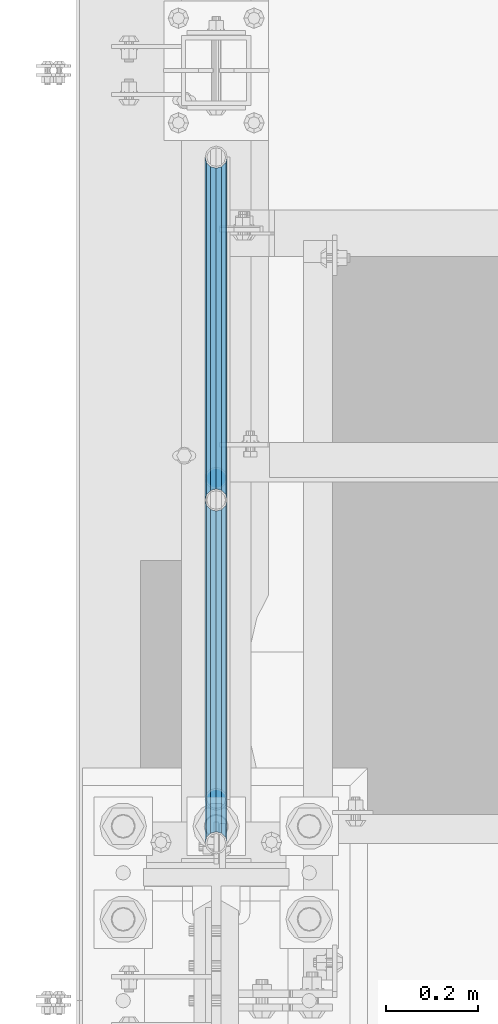
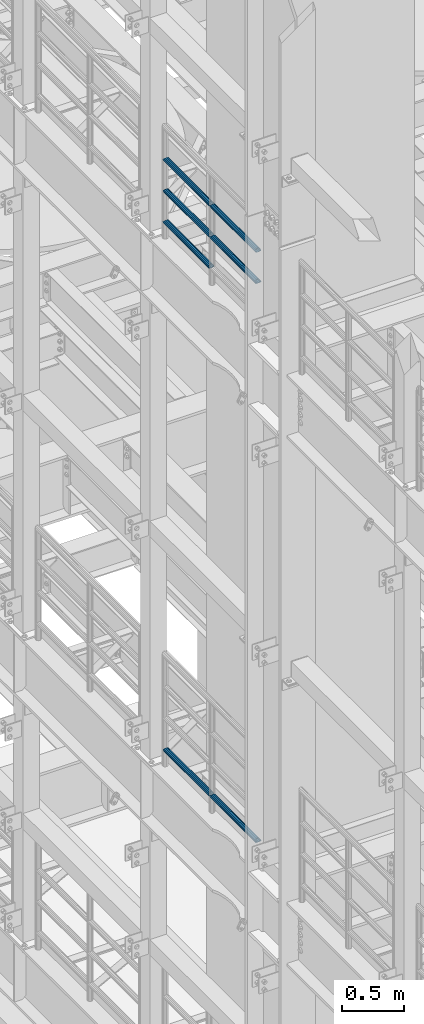
# One storey, part 1245 of 1876: 7 beams, 2 elements without a shape of their own.
"""IFC2X3 building model written with IfcOpenShell, lengths in millimetres."""

from ifc_helpers import new_model, si_unit, frame, origin_with_axes, place, context, subcontext, project, spatial, faceted_brep, material, type_object, element, aggregate, save


model = new_model("IFC2X3")

# Units and contexts
model_context = context("Model", 3, precision=1e-05, world=origin_with_axes())
body_context = subcontext(model_context, "Body", "Model", "MODEL_VIEW")
ifc_project = project(units=[si_unit("LENGTHUNIT", "METRE", prefix="MILLI"), si_unit("AREAUNIT", "SQUARE_METRE"), si_unit("VOLUMEUNIT", "CUBIC_METRE"), si_unit("MASSUNIT", "GRAM", prefix="KILO"), si_unit("TIMEUNIT", "SECOND"), si_unit("PLANEANGLEUNIT", "RADIAN"), si_unit("SOLIDANGLEUNIT", "STERADIAN"), si_unit("THERMODYNAMICTEMPERATUREUNIT", "DEGREE_CELSIUS"), si_unit("LUMINOUSINTENSITYUNIT", "LUMEN")], contexts=[model_context])

# Site, building, storey
site_placement = place(None, origin_with_axes())
site = spatial("IfcSite", under=ifc_project, at=site_placement, CompositionType="ELEMENT")
building_placement = place(site_placement, origin_with_axes())
building = spatial("IfcBuilding", under=site, at=building_placement, Name="Undefined", CompositionType="ELEMENT")
storey_placement = place(building_placement, origin_with_axes())
storey = spatial("IfcBuildingStorey", under=building, at=storey_placement, Name="Undefined", CompositionType="ELEMENT", Elevation=0.0)

# Assembly, beams
assembly_1_placement = place(storey_placement, origin_with_axes())
assembly_1 = element("IfcElementAssembly", 1, at=assembly_1_placement, inside=storey, Name="RAIL", AssemblyPlace="NOTDEFINED", PredefinedType="RIGID_FRAME")
ifc_material = material()
beam_type = type_object("IfcBeamType", Name="PIPE1-1/2SCH40", PredefinedType="NOTDEFINED")
beam_1_placement = place(assembly_1_placement, frame((-1.81898940354586e-12, 3366.77, 13471.525), z_axis=(0.0, 0.0, 1.0), x_axis=(0.0, -1.0, 0.0)))
beam_1 = element("IfcBeam", 2, at=beam_1_placement, type_object=beam_type, material=ifc_material, Name="RAIL", ObjectType="PIPE1-1/2SCH40", context=body_context, shape_type="Brep", body=[
    faceted_brep([(728.085307006683, -12.0649999999996, 20.8971929933177), (728.085307006683, -12.0649999999996, 15.8661214311796), (727.591878568821, -10.2235000000001, 17.7076214311819), (724.852500000002, 0.0, 20.4470000000001), (724.852500000002, 0.0, 24.130000000001), (727.591878568821, 10.2235000000001, 17.7076214311819), (728.085307006683, 12.0649999999996, 15.8661214311796), (728.085307006683, 12.0649999999996, 20.8971929933177), (748.982500000002, 24.1300000000001, 0.0), (736.917500000002, 20.8971929933186, 12.0649999999987), (736.917500000002, 20.8971929933186, -12.0649999999987), (733.727928437864, 17.7076214311801, 10.2235000000001), (736.467307006683, 20.4470000000001, 0.0), (733.727928437864, 17.7076214311801, -10.2235000000001), (728.085307006683, 12.0649999999996, -15.8661214311796), (728.085307006683, 12.0649999999996, -20.8971929933177), (727.591878568821, 10.2235000000001, -17.7076214311819), (724.852500000002, 0.0, -20.4470000000001), (724.852500000002, 0.0, -24.130000000001), (728.085307006683, -12.0649999999996, -15.8661214311796), (728.085307006683, -12.0649999999996, -20.8971929933177), (727.591878568821, -10.2235000000001, -17.7076214311819), (748.982500000002, -24.1300000000001, 0.0), (736.917500000002, -20.8971929933186, -12.0649999999987), (736.917500000002, -20.8971929933186, 12.0649999999987), (733.727928437864, -17.7076214311801, -10.2235000000001), (736.467307006683, -20.4470000000001, 0.0), (733.727928437864, -17.7076214311801, 10.2235000000001), (12.0650000000064, -20.8971929933177, -12.0649999999987), (20.8971929933249, -12.0650000000005, -20.8971929933177), (0.0, 24.1299999999992, 0.0), (12.0650000000064, 20.8971929933177, -12.0649999999987), (12.0650000000064, 20.8971929933177, 12.0649999999987), (20.8971929933249, 12.0650000000005, 20.8971929933177), (24.1300000000064, 0.0, 24.130000000001), (20.8971929933249, 12.0650000000005, -20.8971929933177), (24.1300000000063, 0.0, -24.130000000001), (24.1300000000063, 0.0, -20.4470000000001), (20.8971929933249, -12.0650000000005, -15.8661214311796), (21.3906214311868, -10.2235000000001, -17.7076214311819), (21.3906214311868, 10.2235000000001, -17.7076214311819), (20.8971929933249, 12.0650000000005, -15.8661214311796), (15.2545715621445, 17.7076214311801, -10.2235000000001), (12.5151929933249, 20.4470000000001, 0.0), (15.2545715621445, 17.7076214311801, 10.2235000000001), (20.8971929933249, 12.0650000000005, 15.8661214311796), (21.3906214311868, 10.2235000000001, 17.7076214311819), (24.1300000000064, 0.0, 20.4470000000001), (21.3906214311868, -10.2235000000001, 17.7076214311819), (20.8971929933249, -12.0650000000005, 15.8661214311796), (20.8971929933249, -12.0650000000005, 20.8971929933177), (12.0650000000064, -20.8971929933177, 12.0649999999987), (0.0, -24.1299999999992, 0.0), (15.2545715621445, -17.7076214311801, 10.2235000000001), (12.5151929933249, -20.4470000000001, 0.0), (15.2545715621445, -17.7076214311801, -10.2235000000001)], [[[0, 1, 2, 3, 4]], [[4, 3, 5, 6, 7]], [[8, 9, 10]], [[7, 6, 11, 12, 13, 14, 15, 10, 9]], [[16, 17, 18, 15, 14]], [[19, 20, 18, 17, 21]], [[22, 23, 24]], [[24, 23, 20, 19, 25, 26, 27, 1, 0]], [[28, 29, 20, 23]], [[30, 31, 32]], [[33, 34, 4, 7]], [[32, 33, 7, 9]], [[30, 32, 9, 8]], [[31, 30, 8, 10]], [[35, 31, 10, 15]], [[36, 35, 15, 18]], [[29, 36, 18, 20]], [[37, 36, 29, 38, 39]], [[40, 41, 35, 36, 37]], [[32, 31, 35, 41, 42, 43, 44, 45, 33]], [[33, 45, 46, 47, 34]], [[34, 47, 48, 49, 50]], [[34, 50, 0, 4]], [[50, 51, 24, 0]], [[51, 52, 22, 24]], [[52, 28, 23, 22]], [[51, 28, 52]], [[50, 49, 53, 54, 55, 38, 29, 28, 51]], [[55, 54, 26, 25]], [[21, 39, 38, 55, 25, 19]], [[37, 39, 21, 17]], [[40, 37, 17, 16]], [[42, 41, 40, 16, 14, 13]], [[43, 42, 13, 12]], [[44, 43, 12, 11]], [[5, 46, 45, 44, 11, 6]], [[47, 46, 5, 3]], [[48, 47, 3, 2]], [[53, 49, 48, 2, 1, 27]], [[54, 53, 27, 26]]]),
])
beam_2_placement = place(assembly_1_placement, frame((-1.81898940354586e-12, 1868.805, 13776.325), z_axis=(0.0, 0.0, -1.0), x_axis=(0.0, 1.0, 0.0)))
beam_2 = element("IfcBeam", 3, at=beam_2_placement, type_object=beam_type, material=ifc_material, Name="RAIL", ObjectType="PIPE1-1/2SCH40", context=body_context, shape_type="Brep", body=[
    faceted_brep([(0.0, 24.1299999999992, 0.0), (12.0650000000064, 20.8971929933177, -12.0649999999987), (12.0650000000064, 20.8971929933177, 12.0649999999987), (12.0650000000064, -20.8971929933177, 12.0649999999987), (12.0650000000064, -20.8971929933177, -12.0649999999987), (0.0, -24.1299999999992, 0.0), (20.8971929933249, -12.0650000000005, 20.8971929933177), (20.8971929933249, -12.0650000000005, 15.8661214311796), (15.2545715621445, -17.7076214311801, 10.2235000000001), (12.5151929933249, -20.4470000000001, 0.0), (15.2545715621445, -17.7076214311801, -10.2235000000001), (20.8971929933249, -12.0650000000005, -15.8661214311796), (20.8971929933249, -12.0650000000005, -20.8971929933177), (24.1300000000063, 0.0, -20.4470000000001), (24.1300000000063, 0.0, -24.130000000001), (21.3906214311868, -10.2235000000001, -17.7076214311819), (21.3906214311868, 10.2235000000001, -17.7076214311819), (20.8971929933249, 12.0650000000005, -15.8661214311796), (20.8971929933249, 12.0650000000005, -20.8971929933177), (15.2545715621445, 17.7076214311801, -10.2235000000001), (12.5151929933249, 20.4470000000001, 0.0), (15.2545715621445, 17.7076214311801, 10.2235000000001), (20.8971929933249, 12.0650000000005, 15.8661214311796), (20.8971929933249, 12.0650000000005, 20.8971929933177), (21.3906214311868, 10.2235000000001, 17.7076214311819), (24.1300000000064, 0.0, 20.4470000000001), (24.1300000000064, 0.0, 24.130000000001), (21.3906214311868, -10.2235000000001, 17.7076214311819), (748.982500000002, 24.1300000000001, 0.0), (736.917500000002, 20.8971929933186, -12.0649999999987), (728.085307006683, 12.0649999999996, -20.8971929933177), (748.982500000002, -24.1300000000001, 0.0), (736.917500000002, -20.8971929933186, -12.0649999999987), (736.917500000002, -20.8971929933186, 12.0649999999987), (728.085307006683, -12.0649999999996, 20.8971929933177), (728.085307006683, -12.0649999999996, -20.8971929933177), (724.852500000002, 0.0, -24.130000000001), (727.591878568821, 10.2235000000001, -17.7076214311819), (724.852500000002, 0.0, -20.4470000000001), (728.085307006683, 12.0649999999996, -15.8661214311796), (728.085307006683, -12.0649999999996, -15.8661214311796), (727.591878568821, -10.2235000000001, -17.7076214311819), (733.727928437864, -17.7076214311801, -10.2235000000001), (736.467307006683, -20.4470000000001, 0.0), (733.727928437864, -17.7076214311801, 10.2235000000001), (728.085307006683, -12.0649999999996, 15.8661214311796), (727.591878568821, -10.2235000000001, 17.7076214311819), (724.852500000002, 0.0, 20.4470000000001), (724.852500000002, 0.0, 24.130000000001), (728.085307006683, 12.0649999999996, 20.8971929933177), (736.917500000002, 20.8971929933186, 12.0649999999987), (728.085307006683, 12.0649999999996, 15.8661214311796), (733.727928437864, 17.7076214311801, 10.2235000000001), (736.467307006683, 20.4470000000001, 0.0), (733.727928437864, 17.7076214311801, -10.2235000000001), (727.591878568821, 10.2235000000001, 17.7076214311819)], [[[0, 1, 2]], [[3, 4, 5]], [[6, 7, 8, 9, 10, 11, 12, 4, 3]], [[13, 14, 12, 11, 15]], [[16, 17, 18, 14, 13]], [[2, 1, 18, 17, 19, 20, 21, 22, 23]], [[23, 22, 24, 25, 26]], [[26, 25, 27, 7, 6]], [[1, 0, 28, 29]], [[18, 1, 29, 30]], [[31, 32, 33]], [[6, 3, 33, 34]], [[3, 5, 31, 33]], [[5, 4, 32, 31]], [[4, 12, 35, 32]], [[12, 14, 36, 35]], [[14, 18, 30, 36]], [[37, 38, 36, 30, 39]], [[40, 35, 36, 38, 41]], [[33, 32, 35, 40, 42, 43, 44, 45, 34]], [[34, 45, 46, 47, 48]], [[26, 6, 34, 48]], [[2, 23, 49, 50]], [[23, 26, 48, 49]], [[0, 2, 50, 28]], [[28, 50, 29]], [[49, 51, 52, 53, 54, 39, 30, 29, 50]], [[48, 47, 55, 51, 49]], [[25, 24, 55, 47]], [[55, 24, 22, 21, 52, 51]], [[21, 20, 53, 52]], [[20, 19, 54, 53]], [[19, 17, 16, 37, 39, 54]], [[16, 13, 38, 37]], [[13, 15, 41, 38]], [[41, 15, 11, 10, 42, 40]], [[10, 9, 43, 42]], [[9, 8, 44, 43]], [[8, 7, 27, 46, 45, 44]], [[27, 25, 47, 46]]]),
])
beam_3_placement = place(assembly_1_placement, frame((-1.81898940354586e-12, 2617.7875, 13776.325), z_axis=(0.0, 0.0, -1.0), x_axis=(0.0, 1.0, 0.0)))
beam_3 = element("IfcBeam", 4, at=beam_3_placement, type_object=beam_type, material=ifc_material, Name="RAIL", ObjectType="PIPE1-1/2SCH40", context=body_context, shape_type="Brep", body=[
    faceted_brep([(0.0, 24.1299999999992, 0.0), (12.0650000000064, 20.8971929933177, -12.0649999999987), (12.0650000000064, 20.8971929933177, 12.0649999999987), (12.0650000000064, -20.8971929933177, 12.0649999999987), (12.0650000000064, -20.8971929933177, -12.0649999999987), (0.0, -24.1299999999992, 0.0), (20.8971929933249, -12.0650000000005, 20.8971929933177), (20.8971929933249, -12.0650000000005, 15.8661214311796), (15.2545715621445, -17.7076214311801, 10.2235000000001), (12.5151929933249, -20.4470000000001, 0.0), (15.2545715621445, -17.7076214311801, -10.2235000000001), (20.8971929933249, -12.0650000000005, -15.8661214311796), (20.8971929933249, -12.0650000000005, -20.8971929933177), (24.1300000000063, 0.0, -20.4470000000001), (24.1300000000063, 0.0, -24.130000000001), (21.3906214311868, -10.2235000000001, -17.7076214311819), (21.3906214311868, 10.2235000000001, -17.7076214311819), (20.8971929933249, 12.0650000000005, -15.8661214311796), (20.8971929933249, 12.0650000000005, -20.8971929933177), (15.2545715621445, 17.7076214311801, -10.2235000000001), (12.5151929933249, 20.4470000000001, 0.0), (15.2545715621445, 17.7076214311801, 10.2235000000001), (20.8971929933249, 12.0650000000005, 15.8661214311796), (20.8971929933249, 12.0650000000005, 20.8971929933177), (21.3906214311868, 10.2235000000001, 17.7076214311819), (24.1300000000064, 0.0, 20.4470000000001), (24.1300000000064, 0.0, 24.130000000001), (21.3906214311868, -10.2235000000001, 17.7076214311819), (748.982500000002, 24.1300000000001, 0.0), (736.917500000002, 20.8971929933186, -12.0649999999987), (728.085307006683, 12.0649999999996, -20.8971929933177), (748.982500000002, -24.1300000000001, 0.0), (736.917500000002, -20.8971929933186, -12.0649999999987), (736.917500000002, -20.8971929933186, 12.0649999999987), (728.085307006683, -12.0649999999996, 20.8971929933177), (728.085307006683, -12.0649999999996, -20.8971929933177), (724.852500000002, 0.0, -24.130000000001), (727.591878568821, 10.2235000000001, -17.7076214311819), (724.852500000002, 0.0, -20.4470000000001), (728.085307006683, 12.0649999999996, -15.8661214311796), (728.085307006683, -12.0649999999996, -15.8661214311796), (727.591878568821, -10.2235000000001, -17.7076214311819), (733.727928437864, -17.7076214311801, -10.2235000000001), (736.467307006683, -20.4470000000001, 0.0), (733.727928437864, -17.7076214311801, 10.2235000000001), (728.085307006683, -12.0649999999996, 15.8661214311796), (727.591878568821, -10.2235000000001, 17.7076214311819), (724.852500000002, 0.0, 20.4470000000001), (724.852500000002, 0.0, 24.130000000001), (728.085307006683, 12.0649999999996, 20.8971929933177), (736.917500000002, 20.8971929933186, 12.0649999999987), (728.085307006683, 12.0649999999996, 15.8661214311796), (733.727928437864, 17.7076214311801, 10.2235000000001), (736.467307006683, 20.4470000000001, 0.0), (733.727928437864, 17.7076214311801, -10.2235000000001), (727.591878568821, 10.2235000000001, 17.7076214311819)], [[[0, 1, 2]], [[3, 4, 5]], [[6, 7, 8, 9, 10, 11, 12, 4, 3]], [[13, 14, 12, 11, 15]], [[16, 17, 18, 14, 13]], [[2, 1, 18, 17, 19, 20, 21, 22, 23]], [[23, 22, 24, 25, 26]], [[26, 25, 27, 7, 6]], [[1, 0, 28, 29]], [[18, 1, 29, 30]], [[31, 32, 33]], [[6, 3, 33, 34]], [[3, 5, 31, 33]], [[5, 4, 32, 31]], [[4, 12, 35, 32]], [[12, 14, 36, 35]], [[14, 18, 30, 36]], [[37, 38, 36, 30, 39]], [[40, 35, 36, 38, 41]], [[33, 32, 35, 40, 42, 43, 44, 45, 34]], [[34, 45, 46, 47, 48]], [[26, 6, 34, 48]], [[2, 23, 49, 50]], [[23, 26, 48, 49]], [[0, 2, 50, 28]], [[28, 50, 29]], [[49, 51, 52, 53, 54, 39, 30, 29, 50]], [[48, 47, 55, 51, 49]], [[25, 24, 55, 47]], [[55, 24, 22, 21, 52, 51]], [[21, 20, 53, 52]], [[20, 19, 54, 53]], [[19, 17, 16, 37, 39, 54]], [[16, 13, 38, 37]], [[13, 15, 41, 38]], [[41, 15, 11, 10, 42, 40]], [[10, 9, 43, 42]], [[9, 8, 44, 43]], [[8, 7, 27, 46, 45, 44]], [[27, 25, 47, 46]]]),
])
beam_4_placement = place(assembly_1_placement, frame((-1.81898940354586e-12, 1868.805, 14081.125), z_axis=(0.0, 0.0, -1.0), x_axis=(0.0, 1.0, 0.0)))
beam_4 = element("IfcBeam", 5, at=beam_4_placement, type_object=beam_type, material=ifc_material, Name="RAIL", ObjectType="PIPE1-1/2SCH40", context=body_context, shape_type="Brep", body=[
    faceted_brep([(0.0, 24.1299999999992, 0.0), (12.0650000000064, 20.8971929933177, -12.0649999999987), (12.0650000000064, 20.8971929933177, 12.0649999999987), (12.0650000000064, -20.8971929933177, 12.0649999999987), (12.0650000000064, -20.8971929933177, -12.0649999999987), (0.0, -24.1299999999992, 0.0), (20.8971929933249, -12.0650000000005, 20.8971929933177), (20.8971929933249, -12.0650000000005, 15.8661214311796), (15.2545715621445, -17.7076214311801, 10.2235000000001), (12.5151929933249, -20.4470000000001, 0.0), (15.2545715621445, -17.7076214311801, -10.2235000000001), (20.8971929933249, -12.0650000000005, -15.8661214311796), (20.8971929933249, -12.0650000000005, -20.8971929933177), (24.1300000000063, 0.0, -20.4470000000001), (24.1300000000063, 0.0, -24.130000000001), (21.3906214311868, -10.2235000000001, -17.7076214311819), (21.3906214311868, 10.2235000000001, -17.7076214311819), (20.8971929933249, 12.0650000000005, -15.8661214311796), (20.8971929933249, 12.0650000000005, -20.8971929933177), (15.2545715621445, 17.7076214311801, -10.2235000000001), (12.5151929933249, 20.4470000000001, 0.0), (15.2545715621445, 17.7076214311801, 10.2235000000001), (20.8971929933249, 12.0650000000005, 15.8661214311796), (20.8971929933249, 12.0650000000005, 20.8971929933177), (21.3906214311868, 10.2235000000001, 17.7076214311819), (24.1300000000064, 0.0, 20.4470000000001), (24.1300000000064, 0.0, 24.130000000001), (21.3906214311868, -10.2235000000001, 17.7076214311819), (748.982500000002, 24.1300000000001, 0.0), (736.917500000002, 20.8971929933186, -12.0649999999987), (728.085307006683, 12.0649999999996, -20.8971929933177), (748.982500000002, -24.1300000000001, 0.0), (736.917500000002, -20.8971929933186, -12.0649999999987), (736.917500000002, -20.8971929933186, 12.0649999999987), (728.085307006683, -12.0649999999996, 20.8971929933177), (728.085307006683, -12.0649999999996, -20.8971929933177), (724.852500000002, 0.0, -24.130000000001), (727.591878568821, 10.2235000000001, -17.7076214311819), (724.852500000002, 0.0, -20.4470000000001), (728.085307006683, 12.0649999999996, -15.8661214311796), (728.085307006683, -12.0649999999996, -15.8661214311796), (727.591878568821, -10.2235000000001, -17.7076214311819), (733.727928437864, -17.7076214311801, -10.2235000000001), (736.467307006683, -20.4470000000001, 0.0), (733.727928437864, -17.7076214311801, 10.2235000000001), (728.085307006683, -12.0649999999996, 15.8661214311796), (727.591878568821, -10.2235000000001, 17.7076214311819), (724.852500000002, 0.0, 20.4470000000001), (724.852500000002, 0.0, 24.130000000001), (728.085307006683, 12.0649999999996, 20.8971929933177), (736.917500000002, 20.8971929933186, 12.0649999999987), (728.085307006683, 12.0649999999996, 15.8661214311796), (733.727928437864, 17.7076214311801, 10.2235000000001), (736.467307006683, 20.4470000000001, 0.0), (733.727928437864, 17.7076214311801, -10.2235000000001), (727.591878568821, 10.2235000000001, 17.7076214311819)], [[[0, 1, 2]], [[3, 4, 5]], [[6, 7, 8, 9, 10, 11, 12, 4, 3]], [[13, 14, 12, 11, 15]], [[16, 17, 18, 14, 13]], [[2, 1, 18, 17, 19, 20, 21, 22, 23]], [[23, 22, 24, 25, 26]], [[26, 25, 27, 7, 6]], [[1, 0, 28, 29]], [[18, 1, 29, 30]], [[31, 32, 33]], [[6, 3, 33, 34]], [[3, 5, 31, 33]], [[5, 4, 32, 31]], [[4, 12, 35, 32]], [[12, 14, 36, 35]], [[14, 18, 30, 36]], [[37, 38, 36, 30, 39]], [[40, 35, 36, 38, 41]], [[33, 32, 35, 40, 42, 43, 44, 45, 34]], [[34, 45, 46, 47, 48]], [[26, 6, 34, 48]], [[2, 23, 49, 50]], [[23, 26, 48, 49]], [[0, 2, 50, 28]], [[28, 50, 29]], [[49, 51, 52, 53, 54, 39, 30, 29, 50]], [[48, 47, 55, 51, 49]], [[25, 24, 55, 47]], [[55, 24, 22, 21, 52, 51]], [[21, 20, 53, 52]], [[20, 19, 54, 53]], [[19, 17, 16, 37, 39, 54]], [[16, 13, 38, 37]], [[13, 15, 41, 38]], [[41, 15, 11, 10, 42, 40]], [[10, 9, 43, 42]], [[9, 8, 44, 43]], [[8, 7, 27, 46, 45, 44]], [[27, 25, 47, 46]]]),
])
beam_5_placement = place(assembly_1_placement, frame((-1.81898940354586e-12, 2617.7875, 14081.125), z_axis=(0.0, 0.0, -1.0), x_axis=(0.0, 1.0, 0.0)))
beam_5 = element("IfcBeam", 6, at=beam_5_placement, type_object=beam_type, material=ifc_material, Name="RAIL", ObjectType="PIPE1-1/2SCH40", context=body_context, shape_type="Brep", body=[
    faceted_brep([(0.0, 24.1299999999992, 0.0), (12.0650000000064, 20.8971929933177, -12.0649999999987), (12.0650000000064, 20.8971929933177, 12.0649999999987), (12.0650000000064, -20.8971929933177, 12.0649999999987), (12.0650000000064, -20.8971929933177, -12.0649999999987), (0.0, -24.1299999999992, 0.0), (20.8971929933249, -12.0650000000005, 20.8971929933177), (20.8971929933249, -12.0650000000005, 15.8661214311796), (15.2545715621445, -17.7076214311801, 10.2235000000001), (12.5151929933249, -20.4470000000001, 0.0), (15.2545715621445, -17.7076214311801, -10.2235000000001), (20.8971929933249, -12.0650000000005, -15.8661214311796), (20.8971929933249, -12.0650000000005, -20.8971929933177), (24.1300000000063, 0.0, -20.4470000000001), (24.1300000000063, 0.0, -24.130000000001), (21.3906214311868, -10.2235000000001, -17.7076214311819), (21.3906214311868, 10.2235000000001, -17.7076214311819), (20.8971929933249, 12.0650000000005, -15.8661214311796), (20.8971929933249, 12.0650000000005, -20.8971929933177), (15.2545715621445, 17.7076214311801, -10.2235000000001), (12.5151929933249, 20.4470000000001, 0.0), (15.2545715621445, 17.7076214311801, 10.2235000000001), (20.8971929933249, 12.0650000000005, 15.8661214311796), (20.8971929933249, 12.0650000000005, 20.8971929933177), (21.3906214311868, 10.2235000000001, 17.7076214311819), (24.1300000000064, 0.0, 20.4470000000001), (24.1300000000064, 0.0, 24.130000000001), (21.3906214311868, -10.2235000000001, 17.7076214311819), (748.982500000002, 24.1300000000001, 0.0), (736.917500000002, 20.8971929933186, -12.0649999999987), (728.085307006683, 12.0649999999996, -20.8971929933177), (748.982500000002, -24.1300000000001, 0.0), (736.917500000002, -20.8971929933186, -12.0649999999987), (736.917500000002, -20.8971929933186, 12.0649999999987), (728.085307006683, -12.0649999999996, 20.8971929933177), (728.085307006683, -12.0649999999996, -20.8971929933177), (724.852500000002, 0.0, -24.130000000001), (727.591878568821, 10.2235000000001, -17.7076214311819), (724.852500000002, 0.0, -20.4470000000001), (728.085307006683, 12.0649999999996, -15.8661214311796), (728.085307006683, -12.0649999999996, -15.8661214311796), (727.591878568821, -10.2235000000001, -17.7076214311819), (733.727928437864, -17.7076214311801, -10.2235000000001), (736.467307006683, -20.4470000000001, 0.0), (733.727928437864, -17.7076214311801, 10.2235000000001), (728.085307006683, -12.0649999999996, 15.8661214311796), (727.591878568821, -10.2235000000001, 17.7076214311819), (724.852500000002, 0.0, 20.4470000000001), (724.852500000002, 0.0, 24.130000000001), (728.085307006683, 12.0649999999996, 20.8971929933177), (736.917500000002, 20.8971929933186, 12.0649999999987), (728.085307006683, 12.0649999999996, 15.8661214311796), (733.727928437864, 17.7076214311801, 10.2235000000001), (736.467307006683, 20.4470000000001, 0.0), (733.727928437864, 17.7076214311801, -10.2235000000001), (727.591878568821, 10.2235000000001, 17.7076214311819)], [[[0, 1, 2]], [[3, 4, 5]], [[6, 7, 8, 9, 10, 11, 12, 4, 3]], [[13, 14, 12, 11, 15]], [[16, 17, 18, 14, 13]], [[2, 1, 18, 17, 19, 20, 21, 22, 23]], [[23, 22, 24, 25, 26]], [[26, 25, 27, 7, 6]], [[1, 0, 28, 29]], [[18, 1, 29, 30]], [[31, 32, 33]], [[6, 3, 33, 34]], [[3, 5, 31, 33]], [[5, 4, 32, 31]], [[4, 12, 35, 32]], [[12, 14, 36, 35]], [[14, 18, 30, 36]], [[37, 38, 36, 30, 39]], [[40, 35, 36, 38, 41]], [[33, 32, 35, 40, 42, 43, 44, 45, 34]], [[34, 45, 46, 47, 48]], [[26, 6, 34, 48]], [[2, 23, 49, 50]], [[23, 26, 48, 49]], [[0, 2, 50, 28]], [[28, 50, 29]], [[49, 51, 52, 53, 54, 39, 30, 29, 50]], [[48, 47, 55, 51, 49]], [[25, 24, 55, 47]], [[55, 24, 22, 21, 52, 51]], [[21, 20, 53, 52]], [[20, 19, 54, 53]], [[19, 17, 16, 37, 39, 54]], [[16, 13, 38, 37]], [[13, 15, 41, 38]], [[41, 15, 11, 10, 42, 40]], [[10, 9, 43, 42]], [[9, 8, 44, 43]], [[8, 7, 27, 46, 45, 44]], [[27, 25, 47, 46]]]),
])
aggregate(assembly_1, [beam_1, beam_2, beam_3, beam_4, beam_5])

assembly_2_placement = place(storey_placement, origin_with_axes())
assembly_2 = element("IfcElementAssembly", 7, at=assembly_2_placement, inside=storey, Name="RAIL", AssemblyPlace="NOTDEFINED", PredefinedType="RIGID_FRAME")
beam_6_placement = place(assembly_2_placement, frame((-1.81898940354586e-12, 2617.7875, 8315.325), z_axis=(0.0, 0.0, 1.0), x_axis=(0.0, -1.0, 0.0)))
beam_6 = element("IfcBeam", 8, at=beam_6_placement, type_object=beam_type, material=ifc_material, Name="RAIL", ObjectType="PIPE1-1/2SCH40", context=body_context, shape_type="Brep", body=[
    faceted_brep([(728.085307006683, -12.0649999999996, 20.8971929933177), (728.085307006683, -12.0649999999996, 15.8661214311796), (727.591878568821, -10.2235000000001, 17.7076214311819), (724.852500000002, 0.0, 20.4470000000001), (724.852500000002, 0.0, 24.130000000001), (727.591878568821, 10.2235000000001, 17.7076214311819), (728.085307006683, 12.0649999999996, 15.8661214311796), (728.085307006683, 12.0649999999996, 20.8971929933177), (748.982500000002, 24.1300000000001, 0.0), (736.917500000002, 20.8971929933186, 12.0649999999987), (736.917500000002, 20.8971929933186, -12.0649999999987), (733.727928437864, 17.7076214311801, 10.2235000000001), (736.467307006683, 20.4470000000001, 0.0), (733.727928437864, 17.7076214311801, -10.2235000000001), (728.085307006683, 12.0649999999996, -15.8661214311796), (728.085307006683, 12.0649999999996, -20.8971929933177), (727.591878568821, 10.2235000000001, -17.7076214311819), (724.852500000002, 0.0, -20.4470000000001), (724.852500000002, 0.0, -24.130000000001), (728.085307006683, -12.0649999999996, -15.8661214311796), (728.085307006683, -12.0649999999996, -20.8971929933177), (727.591878568821, -10.2235000000001, -17.7076214311819), (748.982500000002, -24.1300000000001, 0.0), (736.917500000002, -20.8971929933186, -12.0649999999987), (736.917500000002, -20.8971929933186, 12.0649999999987), (733.727928437864, -17.7076214311801, -10.2235000000001), (736.467307006683, -20.4470000000001, 0.0), (733.727928437864, -17.7076214311801, 10.2235000000001), (12.0650000000064, -20.8971929933177, -12.0649999999987), (20.8971929933249, -12.0650000000005, -20.8971929933177), (0.0, 24.1299999999992, 0.0), (12.0650000000064, 20.8971929933177, -12.0649999999987), (12.0650000000064, 20.8971929933177, 12.0649999999987), (20.8971929933249, 12.0650000000005, 20.8971929933177), (24.1300000000064, 0.0, 24.130000000001), (20.8971929933249, 12.0650000000005, -20.8971929933177), (24.1300000000063, 0.0, -24.130000000001), (24.1300000000063, 0.0, -20.4470000000001), (20.8971929933249, -12.0650000000005, -15.8661214311796), (21.3906214311868, -10.2235000000001, -17.7076214311819), (21.3906214311868, 10.2235000000001, -17.7076214311819), (20.8971929933249, 12.0650000000005, -15.8661214311796), (15.2545715621445, 17.7076214311801, -10.2235000000001), (12.5151929933249, 20.4470000000001, 0.0), (15.2545715621445, 17.7076214311801, 10.2235000000001), (20.8971929933249, 12.0650000000005, 15.8661214311796), (21.3906214311868, 10.2235000000001, 17.7076214311819), (24.1300000000064, 0.0, 20.4470000000001), (21.3906214311868, -10.2235000000001, 17.7076214311819), (20.8971929933249, -12.0650000000005, 15.8661214311796), (20.8971929933249, -12.0650000000005, 20.8971929933177), (12.0650000000064, -20.8971929933177, 12.0649999999987), (0.0, -24.1299999999992, 0.0), (15.2545715621445, -17.7076214311801, 10.2235000000001), (12.5151929933249, -20.4470000000001, 0.0), (15.2545715621445, -17.7076214311801, -10.2235000000001)], [[[0, 1, 2, 3, 4]], [[4, 3, 5, 6, 7]], [[8, 9, 10]], [[7, 6, 11, 12, 13, 14, 15, 10, 9]], [[16, 17, 18, 15, 14]], [[19, 20, 18, 17, 21]], [[22, 23, 24]], [[24, 23, 20, 19, 25, 26, 27, 1, 0]], [[28, 29, 20, 23]], [[30, 31, 32]], [[33, 34, 4, 7]], [[32, 33, 7, 9]], [[30, 32, 9, 8]], [[31, 30, 8, 10]], [[35, 31, 10, 15]], [[36, 35, 15, 18]], [[29, 36, 18, 20]], [[37, 36, 29, 38, 39]], [[40, 41, 35, 36, 37]], [[32, 31, 35, 41, 42, 43, 44, 45, 33]], [[33, 45, 46, 47, 34]], [[34, 47, 48, 49, 50]], [[34, 50, 0, 4]], [[50, 51, 24, 0]], [[51, 52, 22, 24]], [[52, 28, 23, 22]], [[51, 28, 52]], [[50, 49, 53, 54, 55, 38, 29, 28, 51]], [[55, 54, 26, 25]], [[21, 39, 38, 55, 25, 19]], [[37, 39, 21, 17]], [[40, 37, 17, 16]], [[42, 41, 40, 16, 14, 13]], [[43, 42, 13, 12]], [[44, 43, 12, 11]], [[5, 46, 45, 44, 11, 6]], [[47, 46, 5, 3]], [[48, 47, 3, 2]], [[53, 49, 48, 2, 1, 27]], [[54, 53, 27, 26]]]),
])
beam_7_placement = place(assembly_2_placement, frame((-1.81898940354586e-12, 3366.77, 8315.325), z_axis=(0.0, 0.0, 1.0), x_axis=(0.0, -1.0, 0.0)))
beam_7 = element("IfcBeam", 9, at=beam_7_placement, type_object=beam_type, material=ifc_material, Name="RAIL", ObjectType="PIPE1-1/2SCH40", context=body_context, shape_type="Brep", body=[
    faceted_brep([(728.085307006683, -12.0649999999996, 20.8971929933177), (728.085307006683, -12.0649999999996, 15.8661214311796), (727.591878568821, -10.2235000000001, 17.7076214311819), (724.852500000002, 0.0, 20.4470000000001), (724.852500000002, 0.0, 24.130000000001), (727.591878568821, 10.2235000000001, 17.7076214311819), (728.085307006683, 12.0649999999996, 15.8661214311796), (728.085307006683, 12.0649999999996, 20.8971929933177), (748.982500000002, 24.1300000000001, 0.0), (736.917500000002, 20.8971929933186, 12.0649999999987), (736.917500000002, 20.8971929933186, -12.0649999999987), (733.727928437864, 17.7076214311801, 10.2235000000001), (736.467307006683, 20.4470000000001, 0.0), (733.727928437864, 17.7076214311801, -10.2235000000001), (728.085307006683, 12.0649999999996, -15.8661214311796), (728.085307006683, 12.0649999999996, -20.8971929933177), (727.591878568821, 10.2235000000001, -17.7076214311819), (724.852500000002, 0.0, -20.4470000000001), (724.852500000002, 0.0, -24.130000000001), (728.085307006683, -12.0649999999996, -15.8661214311796), (728.085307006683, -12.0649999999996, -20.8971929933177), (727.591878568821, -10.2235000000001, -17.7076214311819), (748.982500000002, -24.1300000000001, 0.0), (736.917500000002, -20.8971929933186, -12.0649999999987), (736.917500000002, -20.8971929933186, 12.0649999999987), (733.727928437864, -17.7076214311801, -10.2235000000001), (736.467307006683, -20.4470000000001, 0.0), (733.727928437864, -17.7076214311801, 10.2235000000001), (12.0650000000064, -20.8971929933177, -12.0649999999987), (20.8971929933249, -12.0650000000005, -20.8971929933177), (0.0, 24.1299999999992, 0.0), (12.0650000000064, 20.8971929933177, -12.0649999999987), (12.0650000000064, 20.8971929933177, 12.0649999999987), (20.8971929933249, 12.0650000000005, 20.8971929933177), (24.1300000000064, 0.0, 24.130000000001), (20.8971929933249, 12.0650000000005, -20.8971929933177), (24.1300000000063, 0.0, -24.130000000001), (24.1300000000063, 0.0, -20.4470000000001), (20.8971929933249, -12.0650000000005, -15.8661214311796), (21.3906214311868, -10.2235000000001, -17.7076214311819), (21.3906214311868, 10.2235000000001, -17.7076214311819), (20.8971929933249, 12.0650000000005, -15.8661214311796), (15.2545715621445, 17.7076214311801, -10.2235000000001), (12.5151929933249, 20.4470000000001, 0.0), (15.2545715621445, 17.7076214311801, 10.2235000000001), (20.8971929933249, 12.0650000000005, 15.8661214311796), (21.3906214311868, 10.2235000000001, 17.7076214311819), (24.1300000000064, 0.0, 20.4470000000001), (21.3906214311868, -10.2235000000001, 17.7076214311819), (20.8971929933249, -12.0650000000005, 15.8661214311796), (20.8971929933249, -12.0650000000005, 20.8971929933177), (12.0650000000064, -20.8971929933177, 12.0649999999987), (0.0, -24.1299999999992, 0.0), (15.2545715621445, -17.7076214311801, 10.2235000000001), (12.5151929933249, -20.4470000000001, 0.0), (15.2545715621445, -17.7076214311801, -10.2235000000001)], [[[0, 1, 2, 3, 4]], [[4, 3, 5, 6, 7]], [[8, 9, 10]], [[7, 6, 11, 12, 13, 14, 15, 10, 9]], [[16, 17, 18, 15, 14]], [[19, 20, 18, 17, 21]], [[22, 23, 24]], [[24, 23, 20, 19, 25, 26, 27, 1, 0]], [[28, 29, 20, 23]], [[30, 31, 32]], [[33, 34, 4, 7]], [[32, 33, 7, 9]], [[30, 32, 9, 8]], [[31, 30, 8, 10]], [[35, 31, 10, 15]], [[36, 35, 15, 18]], [[29, 36, 18, 20]], [[37, 36, 29, 38, 39]], [[40, 41, 35, 36, 37]], [[32, 31, 35, 41, 42, 43, 44, 45, 33]], [[33, 45, 46, 47, 34]], [[34, 47, 48, 49, 50]], [[34, 50, 0, 4]], [[50, 51, 24, 0]], [[51, 52, 22, 24]], [[52, 28, 23, 22]], [[51, 28, 52]], [[50, 49, 53, 54, 55, 38, 29, 28, 51]], [[55, 54, 26, 25]], [[21, 39, 38, 55, 25, 19]], [[37, 39, 21, 17]], [[40, 37, 17, 16]], [[42, 41, 40, 16, 14, 13]], [[43, 42, 13, 12]], [[44, 43, 12, 11]], [[5, 46, 45, 44, 11, 6]], [[47, 46, 5, 3]], [[48, 47, 3, 2]], [[53, 49, 48, 2, 1, 27]], [[54, 53, 27, 26]]]),
])
aggregate(assembly_2, [beam_6, beam_7])

save(model, "model.ifc")
